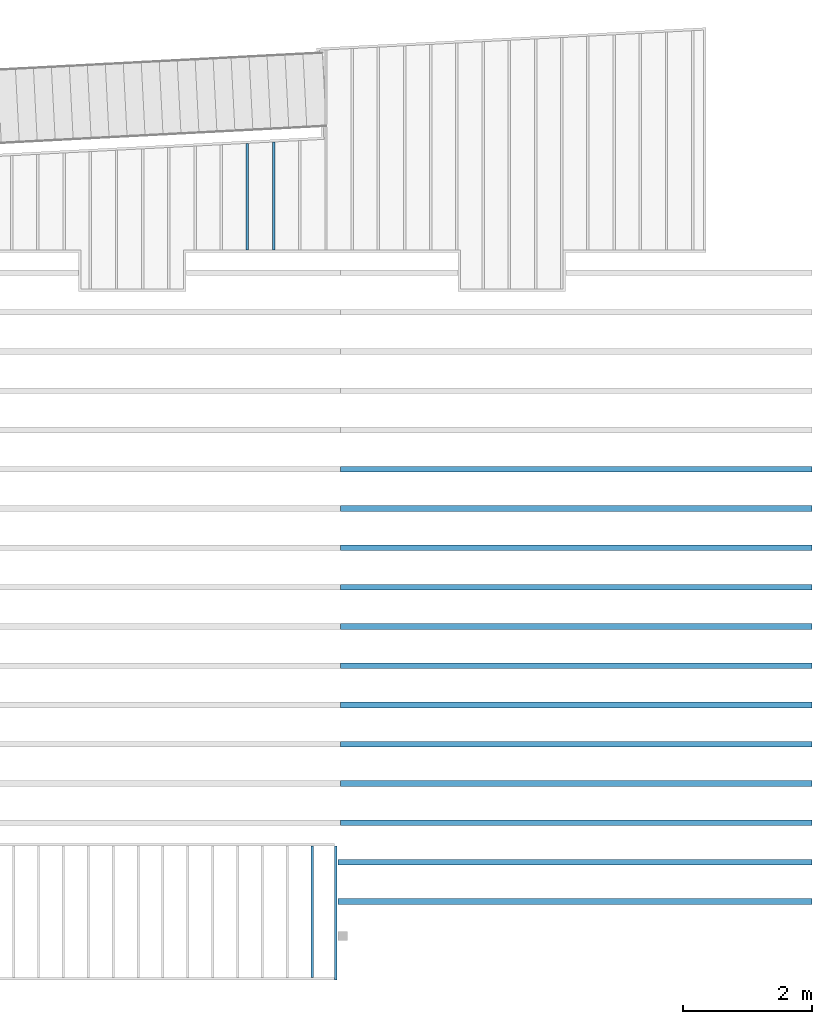
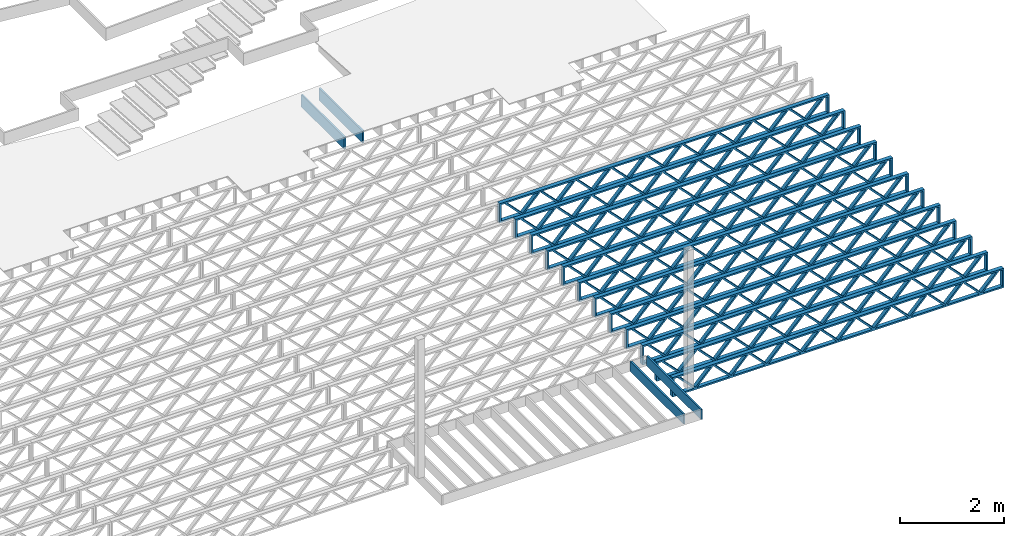
# One storey, part 11 of 23: 16 beams, 3 elements without a shape of their own.
"""IFC4 building model written with IfcOpenShell, lengths in feet."""

from ifc_helpers import new_model, entity, si_unit, converted_unit, derived_unit, direction, frame, frame_2d, origin, origin_2d_with_axis, place, context, subcontext, project, spatial, rectangle, extrude, source, transform, mapped, material, material_profile, profile_set, profile_usage, type_object, type_shapes, element, aggregate, save


model = new_model("IFC4")

# Units and contexts
model_context_1 = context("Model", 3, precision=0.0001, world=origin(), true_north=direction((6.12303176911189e-17, 1.0)))
model_context_2 = context("Model", 3, precision=0.0001, world=origin(), true_north=direction((6.12303176911189e-17, 1.0)))
body_context = subcontext(model_context_2, "Body", "Model", "MODEL_VIEW")
ifc_project = project(units=[converted_unit("LENGTHUNIT", "FOOT", entity("IfcRatioMeasure", 0.3048), si_unit("LENGTHUNIT", "METRE"), dimensions=[1, 0, 0, 0, 0, 0, 0]), converted_unit("AREAUNIT", "SQUARE FOOT", entity("IfcRatioMeasure", 0.09290304), si_unit("AREAUNIT", "SQUARE_METRE"), dimensions=[2, 0, 0, 0, 0, 0, 0]), converted_unit("VOLUMEUNIT", "CUBIC FOOT", entity("IfcRatioMeasure", 0.028316846592), si_unit("VOLUMEUNIT", "CUBIC_METRE"), dimensions=[3, 0, 0, 0, 0, 0, 0]), converted_unit("PLANEANGLEUNIT", "DEGREE", entity("IfcRatioMeasure", 0.0174532925199433), si_unit("PLANEANGLEUNIT", "RADIAN"), dimensions=[0, 0, 0, 0, 0, 0, 0]), si_unit("MASSUNIT", "GRAM", prefix="KILO"), derived_unit("MASSDENSITYUNIT", [(si_unit("MASSUNIT", "GRAM", prefix="KILO"), 1), (si_unit("LENGTHUNIT", "METRE"), -3)]), derived_unit("MOMENTOFINERTIAUNIT", [(si_unit("LENGTHUNIT", "METRE"), 4)]), si_unit("TIMEUNIT", "SECOND"), si_unit("FREQUENCYUNIT", "HERTZ"), si_unit("THERMODYNAMICTEMPERATUREUNIT", "DEGREE_CELSIUS"), derived_unit("THERMALTRANSMITTANCEUNIT", [(si_unit("MASSUNIT", "GRAM", prefix="KILO"), 1), (si_unit("THERMODYNAMICTEMPERATUREUNIT", "KELVIN"), -1), (si_unit("TIMEUNIT", "SECOND"), -3)]), derived_unit("VOLUMETRICFLOWRATEUNIT", [(si_unit("LENGTHUNIT", "METRE"), 3), (si_unit("TIMEUNIT", "SECOND"), -1)]), si_unit("ELECTRICCURRENTUNIT", "AMPERE"), si_unit("ELECTRICVOLTAGEUNIT", "VOLT"), si_unit("POWERUNIT", "WATT"), si_unit("FORCEUNIT", "NEWTON"), si_unit("ILLUMINANCEUNIT", "LUX"), si_unit("LUMINOUSFLUXUNIT", "LUMEN"), si_unit("LUMINOUSINTENSITYUNIT", "CANDELA"), derived_unit("USERDEFINED", [(si_unit("MASSUNIT", "GRAM", prefix="KILO"), -1), (si_unit("LENGTHUNIT", "METRE"), -2), (si_unit("TIMEUNIT", "SECOND"), 3), (si_unit("LUMINOUSFLUXUNIT", "LUMEN"), 1)]), derived_unit("LINEARVELOCITYUNIT", [(si_unit("LENGTHUNIT", "METRE"), 1), (si_unit("TIMEUNIT", "SECOND"), -1)]), si_unit("PRESSUREUNIT", "PASCAL"), derived_unit("USERDEFINED", [(si_unit("LENGTHUNIT", "METRE"), -2), (si_unit("MASSUNIT", "GRAM", prefix="KILO"), 1), (si_unit("TIMEUNIT", "SECOND"), -2)]), derived_unit("LINEARFORCEUNIT", [(si_unit("MASSUNIT", "GRAM", prefix="KILO"), 1), (si_unit("LENGTHUNIT", "METRE"), 1), (si_unit("TIMEUNIT", "SECOND"), -2), (si_unit("LENGTHUNIT", "METRE"), -1)]), derived_unit("PLANARFORCEUNIT", [(si_unit("MASSUNIT", "GRAM", prefix="KILO"), 1), (si_unit("LENGTHUNIT", "METRE"), 1), (si_unit("TIMEUNIT", "SECOND"), -2), (si_unit("LENGTHUNIT", "METRE"), -2)])], contexts=[model_context_1])

# Site, building, storey
site_placement = place(None, origin())
site = spatial("IfcSite", under=ifc_project, at=site_placement, CompositionType="ELEMENT")
building_placement = place(site_placement, origin())
building = spatial("IfcBuilding", under=site, at=building_placement, CompositionType="ELEMENT")
storey_placement = place(building_placement, frame((0.0, 0.0, 10.8020833333333)))
storey = spatial("IfcBuildingStorey", under=building, at=storey_placement, Name="2ND FLOOR", CompositionType="ELEMENT", Elevation=10.8020833333333)

# Assembly, beam
assembly_1_placement = place(storey_placement, origin())
assembly_1 = element("IfcElementAssembly", 1, at=assembly_1_placement, inside=storey, Name="Structural Beam System:Structural Framing System", ObjectType="Structural Beam System:Structural Framing System", AssemblyPlace="NOTDEFINED", PredefinedType="BEAM_GRID")
ifc_material_1 = material(Category="Materials")
ifc_material_profile_1 = material_profile(ifc_material_1, rectangle(XDim=0.9375, YDim=0.125000000000011, at=origin_2d_with_axis()))
ifc_profile_set_1 = profile_set([ifc_material_profile_1])
ifc_profile_usage_1 = profile_usage(ifc_profile_set_1, cardinal=8)
beam_type_1 = type_object("IfcBeamType", PredefinedType="BEAM", material=ifc_profile_set_1)
shared_shape_1 = source(origin(), body_context, "Body", "SweptSolid", [
    extrude(rectangle(XDim=0.9375, YDim=0.125000000000011, at=origin_2d_with_axis()), frame((-2.71281711632207, 0.0, 0.0), z_axis=(1.0, 0.0, 0.0), x_axis=(0.0, 0.0, -1.0)), (0.0, 0.0, 1.0), 5.42563423264414),
])
type_shapes(beam_type_1, [shared_shape_1])
beam_1_placement = place(assembly_1_placement, frame((-169.133993818795, 961.741418759591, -0.729166666666744), z_axis=(0.0, 0.0, 1.0), x_axis=(0.0, 1.0, 0.0)))
beam_1 = element("IfcBeam", 2, at=beam_1_placement, type_object=beam_type_1, material=ifc_profile_usage_1, PredefinedType="BEAM", context=body_context, shape_type="MappedRepresentation", body=[
    mapped(shared_shape_1, transform((0.0, 0.0, 0.0), scale=1.0)),
])

# Assembly, beams
assembly_2_placement = place(storey_placement, origin())
assembly_2 = element("IfcElementAssembly", 3, at=assembly_2_placement, inside=storey, Name="Structural Beam System:Structural Framing System", ObjectType="Structural Beam System:Structural Framing System", AssemblyPlace="NOTDEFINED", PredefinedType="BEAM_GRID")
ifc_material_2 = material(Name="WOOD TRUSS", Category="Materials")
ifc_material_profile_2 = material_profile(ifc_material_2, rectangle(XDim=1.73473973950632, YDim=0.125, at=frame_2d((-1.11022302462516e-16, 8.32667268468867e-17), x_axis=(1.0, 0.0))))
ifc_material_profile_3 = material_profile(ifc_material_2, rectangle(XDim=1.73473973950633, YDim=0.125, at=frame_2d((-1.11022302462516e-16, 8.32667268468867e-17), x_axis=(1.0, 0.0))))
ifc_material_profile_4 = material_profile(ifc_material_2, rectangle(XDim=1.73473973950632, YDim=0.125, at=frame_2d((-5.55111512312578e-17, 1.38777878078145e-16), x_axis=(1.0, 0.0))))
ifc_material_profile_5 = material_profile(ifc_material_2, rectangle(XDim=1.73473973950633, YDim=0.125, at=frame_2d((-1.11022302462516e-16, 8.32667268468867e-17), x_axis=(1.0, 0.0))))
ifc_material_profile_6 = material_profile(ifc_material_2, rectangle(XDim=1.73473973950632, YDim=0.125, at=frame_2d((-1.11022302462516e-16, 8.32667268468867e-17), x_axis=(1.0, 0.0))))
ifc_material_profile_7 = material_profile(ifc_material_2, rectangle(XDim=1.73473973950633, YDim=0.125, at=frame_2d((-2.77555756156289e-16, 3.05311331771918e-16), x_axis=(1.0, 0.0))))
ifc_material_profile_8 = material_profile(ifc_material_2, rectangle(XDim=1.73473973950632, YDim=0.124999999999999, at=frame_2d((-3.88578058618805e-16, -2.4980018054066e-16), x_axis=(1.0, 0.0))))
ifc_material_profile_9 = material_profile(ifc_material_2, rectangle(XDim=1.73473973950633, YDim=0.125, at=frame_2d((2.77555756156289e-16, -3.05311331771918e-16), x_axis=(1.0, 0.0))))
ifc_material_profile_10 = material_profile(ifc_material_2, rectangle(XDim=1.73473973950632, YDim=0.124999999999999, at=frame_2d((-1.11022302462516e-16, 8.32667268468867e-17), x_axis=(1.0, 0.0))))
ifc_material_profile_11 = material_profile(ifc_material_2, rectangle(XDim=1.73473973950633, YDim=0.125, at=origin_2d_with_axis()))
ifc_material_profile_12 = material_profile(ifc_material_2, rectangle(XDim=0.124999999999982, YDim=0.291666666666668, at=origin_2d_with_axis()))
ifc_material_profile_13 = material_profile(ifc_material_2, rectangle(XDim=0.124999999999932, YDim=0.291666666666664, at=origin_2d_with_axis()))
ifc_material_profile_14 = material_profile(ifc_material_2, rectangle(XDim=1.25000000000002, YDim=0.29166666666667, at=origin_2d_with_axis()))
ifc_material_profile_15 = material_profile(ifc_material_2, rectangle(XDim=1.25000000000004, YDim=0.291666666666667, at=origin_2d_with_axis()))
ifc_profile_set_2 = profile_set([ifc_material_profile_2, ifc_material_profile_3, ifc_material_profile_4, ifc_material_profile_5, ifc_material_profile_6, ifc_material_profile_7, ifc_material_profile_8, ifc_material_profile_9, ifc_material_profile_10, ifc_material_profile_11, ifc_material_profile_12, ifc_material_profile_13, ifc_material_profile_14, ifc_material_profile_15])
ifc_profile_usage_2 = profile_usage(ifc_profile_set_2, cardinal=8)
beam_type_2 = type_object("IfcBeamType", PredefinedType="BEAM", material=ifc_profile_set_2)
shared_shape_2 = source(origin(), body_context, "Body", "SweptSolid", [
    extrude(rectangle(XDim=1.73473973950632, YDim=0.124999999999999, at=frame_2d((5.55111512312578e-16, 7.21644966006352e-16), x_axis=(1.0, 0.0))), frame((8.42202085580899, -0.145833333333334, 0.0), z_axis=(0.0, 1.0, 0.0), x_axis=(0.693383046997606, 0.0, 0.720569184836762)), (0.0, 0.0, 1.0), 0.291666666666667),
    extrude(rectangle(XDim=1.73473973950633, YDim=0.125, at=origin_2d_with_axis()), frame((7.17173498213572, -0.145833333333334, 0.0), z_axis=(0.0, 1.0, 0.0), x_axis=(0.69338304699761, 0.0, -0.720569184836758)), (0.0, 0.0, 1.0), 0.291666666666666),
    extrude(rectangle(XDim=1.73473973950632, YDim=0.124999999999999, at=frame_2d((-1.11022302462516e-16, 8.32667268468867e-17), x_axis=(1.0, 0.0))), frame((5.82306154948498, -0.145833333333334, 0.0), z_axis=(0.0, 1.0, 0.0), x_axis=(0.693383046997606, 0.0, 0.720569184836762)), (0.0, 0.0, 1.0), 0.291666666666667),
    extrude(rectangle(XDim=1.73473973950633, YDim=0.125, at=origin_2d_with_axis()), frame((4.57277567581171, -0.145833333333334, 0.0), z_axis=(0.0, 1.0, 0.0), x_axis=(0.69338304699761, 0.0, -0.720569184836758)), (0.0, 0.0, 1.0), 0.291666666666666),
    extrude(rectangle(XDim=1.73473973950632, YDim=0.125, at=frame_2d((2.22044604925031e-16, 3.88578058618805e-16), x_axis=(1.0, 0.0))), frame((3.22410224316097, -0.145833333333334, 0.0), z_axis=(0.0, 1.0, 0.0), x_axis=(0.693383046997606, 0.0, 0.720569184836762)), (0.0, 0.0, 1.0), 0.291666666666667),
    extrude(rectangle(XDim=1.73473973950633, YDim=0.125, at=frame_2d((-1.11022302462516e-16, 8.32667268468867e-17), x_axis=(1.0, 0.0))), frame((1.9738163694877, -0.145833333333334, 0.0), z_axis=(0.0, 1.0, 0.0), x_axis=(0.69338304699761, 0.0, -0.720569184836758)), (0.0, 0.0, 1.0), 0.291666666666667),
    extrude(rectangle(XDim=1.73473973950632, YDim=0.125, at=frame_2d((-5.55111512312578e-17, 1.38777878078145e-16), x_axis=(1.0, 0.0))), frame((0.625142936836964, -0.145833333333334, 0.0), z_axis=(0.0, 1.0, 0.0), x_axis=(0.693383046997606, 0.0, 0.720569184836762)), (0.0, 0.0, 1.0), 0.291666666666667),
    extrude(rectangle(XDim=1.73473973950633, YDim=0.125, at=frame_2d((-1.11022302462516e-16, 8.32667268468867e-17), x_axis=(1.0, 0.0))), frame((-0.625142936836306, -0.145833333333334, 0.0), z_axis=(0.0, 1.0, 0.0), x_axis=(0.69338304699761, 0.0, -0.720569184836758)), (0.0, 0.0, 1.0), 0.291666666666667),
    extrude(rectangle(XDim=1.73473973950632, YDim=0.125, at=frame_2d((-1.11022302462516e-16, 8.32667268468867e-17), x_axis=(1.0, 0.0))), frame((-1.97381636948704, -0.145833333333334, 0.0), z_axis=(0.0, 1.0, 0.0), x_axis=(0.693383046997606, 0.0, 0.720569184836762)), (0.0, 0.0, 1.0), 0.291666666666667),
    extrude(rectangle(XDim=1.73473973950633, YDim=0.125, at=origin_2d_with_axis()), frame((-3.22410224316031, -0.145833333333334, 0.0), z_axis=(0.0, 1.0, 0.0), x_axis=(0.69338304699761, 0.0, -0.720569184836758)), (0.0, 0.0, 1.0), 0.291666666666667),
    extrude(rectangle(XDim=1.73473973950632, YDim=0.124999999999999, at=frame_2d((-1.11022302462516e-16, 8.32667268468867e-17), x_axis=(1.0, 0.0))), frame((-4.57277567581105, -0.145833333333334, 0.0), z_axis=(0.0, 1.0, 0.0), x_axis=(0.693383046997606, 0.0, 0.720569184836762)), (0.0, 0.0, 1.0), 0.291666666666667),
    extrude(rectangle(XDim=1.73473973950633, YDim=0.125, at=origin_2d_with_axis()), frame((-5.82306154948432, -0.145833333333334, 0.0), z_axis=(0.0, 1.0, 0.0), x_axis=(0.69338304699761, 0.0, -0.720569184836758)), (0.0, 0.0, 1.0), 0.291666666666666),
    extrude(rectangle(XDim=1.73473973950632, YDim=0.124999999999999, at=frame_2d((-1.11022302462516e-16, 8.32667268468867e-17), x_axis=(1.0, 0.0))), frame((-7.17173498213506, -0.145833333333334, 0.0), z_axis=(0.0, 1.0, 0.0), x_axis=(0.693383046997606, 0.0, 0.720569184836762)), (0.0, 0.0, 1.0), 0.291666666666667),
    extrude(rectangle(XDim=1.73473973950633, YDim=0.125, at=frame_2d((-2.77555756156289e-16, 3.05311331771918e-16), x_axis=(1.0, 0.0))), frame((-8.42202085580833, -0.145833333333334, 0.0), z_axis=(0.0, 1.0, 0.0), x_axis=(0.69338304699761, 0.0, -0.720569184836758)), (0.0, 0.0, 1.0), 0.291666666666666),
    extrude(rectangle(XDim=1.73473973950632, YDim=0.125, at=frame_2d((-7.21644966006352e-16, -5.55111512312578e-16), x_axis=(1.0, 0.0))), frame((11.020980162133, -0.145833333333334, 0.0), z_axis=(0.0, 1.0, 0.0), x_axis=(0.693383046997606, 0.0, 0.720569184836762)), (0.0, 0.0, 1.0), 0.291666666666667),
    extrude(rectangle(XDim=1.73473973950633, YDim=0.125, at=origin_2d_with_axis()), frame((9.77069428845972, -0.145833333333334, 0.0), z_axis=(0.0, 1.0, 0.0), x_axis=(0.69338304699761, 0.0, -0.720569184836758)), (0.0, 0.0, 1.0), 0.291666666666666),
    extrude(rectangle(XDim=1.73473973950632, YDim=0.125, at=frame_2d((-5.55111512312578e-17, 8.32667268468867e-17), x_axis=(1.0, 0.0))), frame((-9.77069428845906, -0.145833333333334, 0.0), z_axis=(0.0, 1.0, 0.0), x_axis=(0.693383046997606, 0.0, 0.720569184836762)), (0.0, 0.0, 1.0), 0.291666666666667),
    extrude(rectangle(XDim=1.73473973950633, YDim=0.125, at=origin_2d_with_axis()), frame((-11.0209801621323, -0.145833333333334, 0.0), z_axis=(0.0, 1.0, 0.0), x_axis=(0.69338304699761, 0.0, -0.720569184836758)), (0.0, 0.0, 1.0), 0.291666666666666),
    extrude(rectangle(XDim=0.124999999999982, YDim=0.291666666666668, at=origin_2d_with_axis()), frame((-12.0625038919626, 0.0, 0.687500000000054), z_axis=(1.0, 0.0, 0.0), x_axis=(0.0, 0.0, -1.0)), (0.0, 0.0, 1.0), 24.1250077839252),
    extrude(rectangle(XDim=0.124999999999932, YDim=0.291666666666664, at=origin_2d_with_axis()), frame((-12.0625038919624, 0.0, -0.687499999999984), z_axis=(1.0, 0.0, 0.0), x_axis=(0.0, 0.0, -1.0)), (0.0, 0.0, 1.0), 24.125007783925),
    extrude(rectangle(XDim=1.25000000000002, YDim=0.29166666666667, at=origin_2d_with_axis()), frame((11.9375038919626, 0.0, 0.0), z_axis=(1.0, 0.0, 0.0), x_axis=(0.0, 0.0, -1.0)), (0.0, 0.0, 1.0), 0.12500000000002),
    extrude(rectangle(XDim=1.25000000000004, YDim=0.291666666666667, at=origin_2d_with_axis()), frame((-12.0625038919626, 0.0, 0.0), z_axis=(1.0, 0.0, 0.0), x_axis=(0.0, 0.0, -1.0)), (0.0, 0.0, 1.0), 0.125000000000023),
])
type_shapes(beam_type_2, [shared_shape_2])
beam_2_placement = place(assembly_2_placement, frame((-152.467323260299, 927.861934882651, -0.947916666657859), z_axis=(0.0, 0.0, 1.0), x_axis=(-1.0, 0.0, 0.0)))
beam_2 = element("IfcBeam", 4, at=beam_2_placement, type_object=beam_type_2, material=ifc_profile_usage_2, PredefinedType="BEAM", context=body_context, shape_type="MappedRepresentation", body=[
    mapped(shared_shape_2, transform((0.0, 0.0, 0.0), scale=1.0)),
])
ifc_profile_usage_3 = profile_usage(ifc_profile_set_2, cardinal=8)
beam_3_placement = place(assembly_2_placement, frame((-152.467323260299, 925.861934882651, -0.947916666657859), z_axis=(0.0, 0.0, 1.0), x_axis=(-1.0, 0.0, 0.0)))
beam_3 = element("IfcBeam", 5, at=beam_3_placement, type_object=beam_type_2, material=ifc_profile_usage_3, PredefinedType="BEAM", context=body_context, shape_type="MappedRepresentation", body=[
    mapped(shared_shape_2, transform((0.0, 0.0, 0.0), scale=1.0)),
])

# Assembly, beam
assembly_3_placement = place(storey_placement, origin())
assembly_3 = element("IfcElementAssembly", 6, at=assembly_3_placement, inside=storey, Name="Structural Beam System:Structural Framing System", ObjectType="Structural Beam System:Structural Framing System", AssemblyPlace="NOTDEFINED", PredefinedType="BEAM_GRID")
ifc_material_profile_16 = material_profile(ifc_material_1, rectangle(XDim=0.770833333333333, YDim=0.124999999999994, at=frame_2d((-5.55111512312578e-17, 0.0), x_axis=(1.0, 0.0))))
ifc_profile_set_3 = profile_set([ifc_material_profile_16])
ifc_profile_usage_4 = profile_usage(ifc_profile_set_3, cardinal=8)
beam_type_3 = type_object("IfcBeamType", PredefinedType="BEAM", material=ifc_profile_set_3)
shared_shape_3 = source(origin(), body_context, "Body", "SweptSolid", [
    extrude(rectangle(XDim=0.770833333333333, YDim=0.124999999999994, at=frame_2d((-5.55111512312578e-17, 0.0), x_axis=(1.0, 0.0))), frame((-3.35416666666737, 0.0, 0.0), z_axis=(1.0, 0.0, 0.0), x_axis=(0.0, 0.0, -1.0)), (0.0, 0.0, 1.0), 6.70833333333462),
])
type_shapes(beam_type_3, [shared_shape_3])
beam_4_placement = place(assembly_3_placement, frame((-165.83512302263, 925.341101549316, -0.645833333333471), z_axis=(0.0, 0.0, 1.0), x_axis=(0.0, 1.0, 0.0)))
beam_4 = element("IfcBeam", 7, at=beam_4_placement, type_object=beam_type_3, material=ifc_profile_usage_4, PredefinedType="BEAM", context=body_context, shape_type="MappedRepresentation", body=[
    mapped(shared_shape_3, transform((0.0, 0.0, 0.0), scale=1.0)),
])
aggregate(assembly_3, [beam_4])

# Beam
ifc_profile_usage_5 = profile_usage(ifc_profile_set_3, cardinal=8)
beam_type_4 = type_object("IfcBeamType", PredefinedType="BEAM", material=ifc_profile_set_3)
shared_shape_4 = source(origin(), body_context, "Body", "SweptSolid", [
    extrude(rectangle(XDim=0.770833333333333, YDim=0.124999999999994, at=frame_2d((-5.55111512312578e-17, 0.0), x_axis=(1.0, 0.0))), frame((-3.47916666666737, 0.0, 0.0), z_axis=(1.0, 0.0, 0.0), x_axis=(0.0, 0.0, -1.0)), (0.0, 0.0, 1.0), 6.83333333333485),
])
type_shapes(beam_type_4, [shared_shape_4])
beam_5_placement = place(storey_placement, frame((-164.633993818862, 925.341101549316, -0.645833333332796), z_axis=(0.0, 0.0, 1.0), x_axis=(0.0, 1.0, 0.0)))
element("IfcBeam", 8, at=beam_5_placement, inside=storey, type_object=beam_type_4, material=ifc_profile_usage_5, PredefinedType="BEAM", context=body_context, shape_type="MappedRepresentation", body=[
    mapped(shared_shape_4, transform((0.0, 0.0, 0.0), scale=1.0)),
])

ifc_profile_usage_6 = profile_usage(ifc_profile_set_1, cardinal=8)
beam_type_5 = type_object("IfcBeamType", PredefinedType="BEAM", material=ifc_profile_set_1)
shared_shape_5 = source(origin(), body_context, "Body", "SweptSolid", [
    extrude(rectangle(XDim=0.9375, YDim=0.125000000000011, at=origin_2d_with_axis()), frame((-2.7477554683428, 0.0, 0.0), z_axis=(1.0, 0.0, 0.0), x_axis=(0.0, 0.0, -1.0)), (0.0, 0.0, 1.0), 5.49551093668561),
])
type_shapes(beam_type_5, [shared_shape_5])
beam_6_placement = place(assembly_1_placement, frame((-167.800660485462, 961.776357446614, -0.729166666666744), z_axis=(0.0, 0.0, 1.0), x_axis=(0.0, 1.0, 0.0)))
beam_6 = element("IfcBeam", 9, at=beam_6_placement, type_object=beam_type_5, material=ifc_profile_usage_6, PredefinedType="BEAM", context=body_context, shape_type="MappedRepresentation", body=[
    mapped(shared_shape_5, transform((0.0, 0.0, 0.0), scale=1.0)),
])

aggregate(assembly_1, [beam_1, beam_6])

ifc_profile_usage_7 = profile_usage(ifc_profile_set_2, cardinal=8)
beam_type_6 = type_object("IfcBeamType", PredefinedType="BEAM", material=ifc_profile_set_2)
shared_shape_6 = source(origin(), body_context, "Body", "SweptSolid", [
    extrude(rectangle(XDim=1.73473973950632, YDim=0.124999999999999, at=frame_2d((5.55111512312578e-16, 7.21644966006352e-16), x_axis=(1.0, 0.0))), frame((8.37514585578398, -0.145833333333334, 0.0), z_axis=(0.0, 1.0, 0.0), x_axis=(0.693383046997606, 0.0, 0.720569184836762)), (0.0, 0.0, 1.0), 0.291666666666667),
    extrude(rectangle(XDim=1.73473973950633, YDim=0.125, at=origin_2d_with_axis()), frame((7.12485998211071, -0.145833333333334, 0.0), z_axis=(0.0, 1.0, 0.0), x_axis=(0.69338304699761, 0.0, -0.720569184836758)), (0.0, 0.0, 1.0), 0.291666666666666),
    extrude(rectangle(XDim=1.73473973950632, YDim=0.124999999999999, at=frame_2d((-1.11022302462516e-16, 8.32667268468867e-17), x_axis=(1.0, 0.0))), frame((5.79181154946831, -0.145833333333334, 0.0), z_axis=(0.0, 1.0, 0.0), x_axis=(0.693383046997606, 0.0, 0.720569184836762)), (0.0, 0.0, 1.0), 0.291666666666667),
    extrude(rectangle(XDim=1.73473973950633, YDim=0.125, at=origin_2d_with_axis()), frame((4.54152567579504, -0.145833333333334, 0.0), z_axis=(0.0, 1.0, 0.0), x_axis=(0.69338304699761, 0.0, -0.720569184836758)), (0.0, 0.0, 1.0), 0.291666666666666),
    extrude(rectangle(XDim=1.73473973950632, YDim=0.125, at=frame_2d((2.22044604925031e-16, 3.88578058618805e-16), x_axis=(1.0, 0.0))), frame((3.20847724315264, -0.145833333333334, 0.0), z_axis=(0.0, 1.0, 0.0), x_axis=(0.693383046997606, 0.0, 0.720569184836762)), (0.0, 0.0, 1.0), 0.291666666666667),
    extrude(rectangle(XDim=1.73473973950633, YDim=0.125, at=frame_2d((-1.11022302462516e-16, 8.32667268468867e-17), x_axis=(1.0, 0.0))), frame((1.95819136947937, -0.145833333333334, 0.0), z_axis=(0.0, 1.0, 0.0), x_axis=(0.69338304699761, 0.0, -0.720569184836758)), (0.0, 0.0, 1.0), 0.291666666666667),
    extrude(rectangle(XDim=1.73473973950632, YDim=0.125, at=frame_2d((-5.55111512312578e-17, 1.38777878078145e-16), x_axis=(1.0, 0.0))), frame((0.625142936836964, -0.145833333333334, 0.0), z_axis=(0.0, 1.0, 0.0), x_axis=(0.693383046997606, 0.0, 0.720569184836762)), (0.0, 0.0, 1.0), 0.291666666666667),
    extrude(rectangle(XDim=1.73473973950633, YDim=0.125, at=frame_2d((-1.11022302462516e-16, 8.32667268468867e-17), x_axis=(1.0, 0.0))), frame((-0.625142936836306, -0.145833333333334, 0.0), z_axis=(0.0, 1.0, 0.0), x_axis=(0.69338304699761, 0.0, -0.720569184836758)), (0.0, 0.0, 1.0), 0.291666666666667),
    extrude(rectangle(XDim=1.73473973950632, YDim=0.125, at=frame_2d((-1.11022302462516e-16, 8.32667268468867e-17), x_axis=(1.0, 0.0))), frame((-1.95819136947871, -0.145833333333334, 0.0), z_axis=(0.0, 1.0, 0.0), x_axis=(0.693383046997606, 0.0, 0.720569184836762)), (0.0, 0.0, 1.0), 0.291666666666667),
    extrude(rectangle(XDim=1.73473973950633, YDim=0.125, at=origin_2d_with_axis()), frame((-3.20847724315198, -0.145833333333334, 0.0), z_axis=(0.0, 1.0, 0.0), x_axis=(0.69338304699761, 0.0, -0.720569184836758)), (0.0, 0.0, 1.0), 0.291666666666667),
    extrude(rectangle(XDim=1.73473973950632, YDim=0.124999999999999, at=frame_2d((-1.11022302462516e-16, 8.32667268468867e-17), x_axis=(1.0, 0.0))), frame((-4.54152567579438, -0.145833333333334, 0.0), z_axis=(0.0, 1.0, 0.0), x_axis=(0.693383046997606, 0.0, 0.720569184836762)), (0.0, 0.0, 1.0), 0.291666666666667),
    extrude(rectangle(XDim=1.73473973950633, YDim=0.125, at=origin_2d_with_axis()), frame((-5.79181154946765, -0.145833333333334, 0.0), z_axis=(0.0, 1.0, 0.0), x_axis=(0.69338304699761, 0.0, -0.720569184836758)), (0.0, 0.0, 1.0), 0.291666666666666),
    extrude(rectangle(XDim=1.73473973950632, YDim=0.124999999999999, at=frame_2d((-1.11022302462516e-16, 8.32667268468867e-17), x_axis=(1.0, 0.0))), frame((-7.12485998211005, -0.145833333333334, 0.0), z_axis=(0.0, 1.0, 0.0), x_axis=(0.693383046997606, 0.0, 0.720569184836762)), (0.0, 0.0, 1.0), 0.291666666666667),
    extrude(rectangle(XDim=1.73473973950633, YDim=0.125, at=frame_2d((-2.77555756156289e-16, 3.05311331771918e-16), x_axis=(1.0, 0.0))), frame((-8.37514585578332, -0.145833333333334, 0.0), z_axis=(0.0, 1.0, 0.0), x_axis=(0.69338304699761, 0.0, -0.720569184836758)), (0.0, 0.0, 1.0), 0.291666666666666),
    extrude(rectangle(XDim=1.73473973950632, YDim=0.125, at=frame_2d((-7.21644966006352e-16, -5.55111512312578e-16), x_axis=(1.0, 0.0))), frame((10.9584801620997, -0.145833333333334, 0.0), z_axis=(0.0, 1.0, 0.0), x_axis=(0.693383046997606, 0.0, 0.720569184836762)), (0.0, 0.0, 1.0), 0.291666666666667),
    extrude(rectangle(XDim=1.73473973950633, YDim=0.125, at=origin_2d_with_axis()), frame((9.70819428842638, -0.145833333333334, 0.0), z_axis=(0.0, 1.0, 0.0), x_axis=(0.69338304699761, 0.0, -0.720569184836758)), (0.0, 0.0, 1.0), 0.291666666666666),
    extrude(rectangle(XDim=1.73473973950632, YDim=0.125, at=frame_2d((-5.55111512312578e-17, 8.32667268468867e-17), x_axis=(1.0, 0.0))), frame((-9.70819428842572, -0.145833333333334, 0.0), z_axis=(0.0, 1.0, 0.0), x_axis=(0.693383046997606, 0.0, 0.720569184836762)), (0.0, 0.0, 1.0), 0.291666666666667),
    extrude(rectangle(XDim=1.73473973950633, YDim=0.125, at=origin_2d_with_axis()), frame((-10.958480162099, -0.145833333333334, 0.0), z_axis=(0.0, 1.0, 0.0), x_axis=(0.69338304699761, 0.0, -0.720569184836758)), (0.0, 0.0, 1.0), 0.291666666666666),
    extrude(rectangle(XDim=0.124999999999982, YDim=0.291666666666668, at=origin_2d_with_axis()), frame((-12.0000038919293, 0.0, 0.687500000000054), z_axis=(1.0, 0.0, 0.0), x_axis=(0.0, 0.0, -1.0)), (0.0, 0.0, 1.0), 24.0000077838585),
    extrude(rectangle(XDim=0.124999999999932, YDim=0.291666666666664, at=origin_2d_with_axis()), frame((-12.0000038919291, 0.0, -0.687499999999984), z_axis=(1.0, 0.0, 0.0), x_axis=(0.0, 0.0, -1.0)), (0.0, 0.0, 1.0), 24.0000077838583),
    extrude(rectangle(XDim=1.25000000000002, YDim=0.29166666666667, at=origin_2d_with_axis()), frame((11.8750038919292, 0.0, 0.0), z_axis=(1.0, 0.0, 0.0), x_axis=(0.0, 0.0, -1.0)), (0.0, 0.0, 1.0), 0.12500000000002),
    extrude(rectangle(XDim=1.25000000000004, YDim=0.291666666666667, at=origin_2d_with_axis()), frame((-12.0000038919293, 0.0, 0.0), z_axis=(1.0, 0.0, 0.0), x_axis=(0.0, 0.0, -1.0)), (0.0, 0.0, 1.0), 0.125000000000023),
])
type_shapes(beam_type_6, [shared_shape_6])
beam_7_placement = place(assembly_2_placement, frame((-152.404823260266, 931.861934882651, -0.947916666657859), z_axis=(0.0, 0.0, 1.0), x_axis=(-1.0, 0.0, 0.0)))
beam_7 = element("IfcBeam", 10, at=beam_7_placement, type_object=beam_type_6, material=ifc_profile_usage_7, PredefinedType="BEAM", context=body_context, shape_type="MappedRepresentation", body=[
    mapped(shared_shape_6, transform((0.0, 0.0, 0.0), scale=1.0)),
])

ifc_profile_usage_8 = profile_usage(ifc_profile_set_2, cardinal=8)
beam_8_placement = place(assembly_2_placement, frame((-152.404823260266, 937.861934882651, -0.947916666657859), z_axis=(0.0, 0.0, 1.0), x_axis=(-1.0, 0.0, 0.0)))
beam_8 = element("IfcBeam", 11, at=beam_8_placement, type_object=beam_type_6, material=ifc_profile_usage_8, PredefinedType="BEAM", context=body_context, shape_type="MappedRepresentation", body=[
    mapped(shared_shape_6, transform((0.0, 0.0, 0.0), scale=1.0)),
])

ifc_profile_usage_9 = profile_usage(ifc_profile_set_2, cardinal=8)
beam_9_placement = place(assembly_2_placement, frame((-152.404823260266, 945.861934882651, -0.947916666657859), z_axis=(0.0, 0.0, 1.0), x_axis=(-1.0, 0.0, 0.0)))
beam_9 = element("IfcBeam", 12, at=beam_9_placement, type_object=beam_type_6, material=ifc_profile_usage_9, PredefinedType="BEAM", context=body_context, shape_type="MappedRepresentation", body=[
    mapped(shared_shape_6, transform((0.0, 0.0, 0.0), scale=1.0)),
])

ifc_profile_usage_10 = profile_usage(ifc_profile_set_2, cardinal=8)
beam_10_placement = place(assembly_2_placement, frame((-152.404823260266, 947.861934882651, -0.947916666657859), z_axis=(0.0, 0.0, 1.0), x_axis=(-1.0, 0.0, 0.0)))
beam_10 = element("IfcBeam", 13, at=beam_10_placement, type_object=beam_type_6, material=ifc_profile_usage_10, PredefinedType="BEAM", context=body_context, shape_type="MappedRepresentation", body=[
    mapped(shared_shape_6, transform((0.0, 0.0, 0.0), scale=1.0)),
])

ifc_profile_usage_11 = profile_usage(ifc_profile_set_2, cardinal=8)
beam_11_placement = place(assembly_2_placement, frame((-152.404823260266, 929.861934882651, -0.947916666657859), z_axis=(0.0, 0.0, 1.0), x_axis=(-1.0, 0.0, 0.0)))
beam_11 = element("IfcBeam", 14, at=beam_11_placement, type_object=beam_type_6, material=ifc_profile_usage_11, PredefinedType="BEAM", context=body_context, shape_type="MappedRepresentation", body=[
    mapped(shared_shape_6, transform((0.0, 0.0, 0.0), scale=1.0)),
])

ifc_profile_usage_12 = profile_usage(ifc_profile_set_2, cardinal=8)
beam_12_placement = place(assembly_2_placement, frame((-152.404823260266, 933.861934882651, -0.947916666657859), z_axis=(0.0, 0.0, 1.0), x_axis=(-1.0, 0.0, 0.0)))
beam_12 = element("IfcBeam", 15, at=beam_12_placement, type_object=beam_type_6, material=ifc_profile_usage_12, PredefinedType="BEAM", context=body_context, shape_type="MappedRepresentation", body=[
    mapped(shared_shape_6, transform((0.0, 0.0, 0.0), scale=1.0)),
])

ifc_profile_usage_13 = profile_usage(ifc_profile_set_2, cardinal=8)
beam_13_placement = place(assembly_2_placement, frame((-152.404823260266, 939.861934882651, -0.947916666657859), z_axis=(0.0, 0.0, 1.0), x_axis=(-1.0, 0.0, 0.0)))
beam_13 = element("IfcBeam", 16, at=beam_13_placement, type_object=beam_type_6, material=ifc_profile_usage_13, PredefinedType="BEAM", context=body_context, shape_type="MappedRepresentation", body=[
    mapped(shared_shape_6, transform((0.0, 0.0, 0.0), scale=1.0)),
])

ifc_profile_usage_14 = profile_usage(ifc_profile_set_2, cardinal=8)
beam_14_placement = place(assembly_2_placement, frame((-152.404823260266, 941.861934882651, -0.947916666657859), z_axis=(0.0, 0.0, 1.0), x_axis=(-1.0, 0.0, 0.0)))
beam_14 = element("IfcBeam", 17, at=beam_14_placement, type_object=beam_type_6, material=ifc_profile_usage_14, PredefinedType="BEAM", context=body_context, shape_type="MappedRepresentation", body=[
    mapped(shared_shape_6, transform((0.0, 0.0, 0.0), scale=1.0)),
])

ifc_profile_usage_15 = profile_usage(ifc_profile_set_2, cardinal=8)
beam_15_placement = place(assembly_2_placement, frame((-152.404823260266, 943.861934882651, -0.947916666657859), z_axis=(0.0, 0.0, 1.0), x_axis=(-1.0, 0.0, 0.0)))
beam_15 = element("IfcBeam", 18, at=beam_15_placement, type_object=beam_type_6, material=ifc_profile_usage_15, PredefinedType="BEAM", context=body_context, shape_type="MappedRepresentation", body=[
    mapped(shared_shape_6, transform((0.0, 0.0, 0.0), scale=1.0)),
])

ifc_profile_usage_16 = profile_usage(ifc_profile_set_2, cardinal=8)
beam_16_placement = place(assembly_2_placement, frame((-152.404823260266, 935.861934882651, -0.947916666657859), z_axis=(0.0, 0.0, 1.0), x_axis=(-1.0, 0.0, 0.0)))
beam_16 = element("IfcBeam", 19, at=beam_16_placement, type_object=beam_type_6, material=ifc_profile_usage_16, PredefinedType="BEAM", context=body_context, shape_type="MappedRepresentation", body=[
    mapped(shared_shape_6, transform((0.0, 0.0, 0.0), scale=1.0)),
])

aggregate(assembly_2, [beam_2, beam_3, beam_7, beam_8, beam_9, beam_10, beam_11, beam_12, beam_13, beam_14, beam_15, beam_16])

save(model, "model.ifc")
